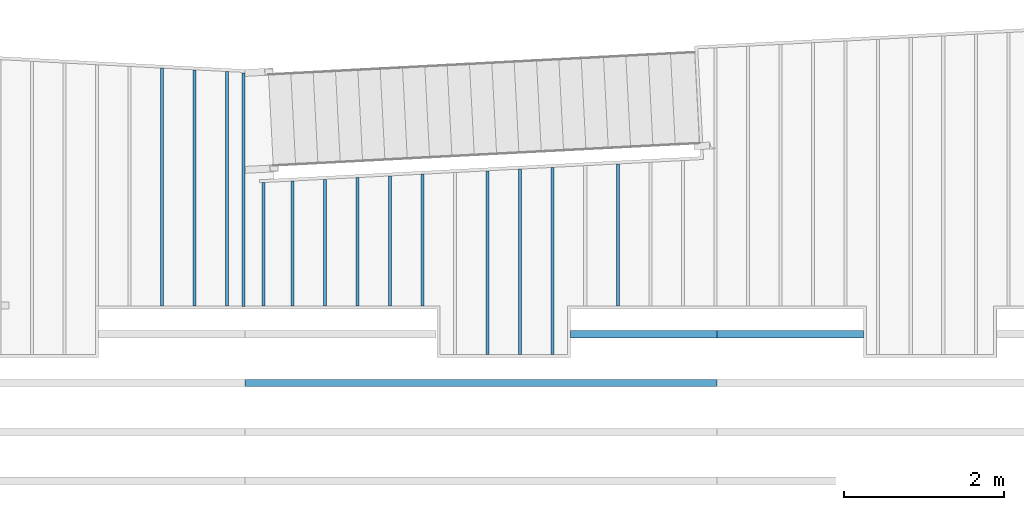
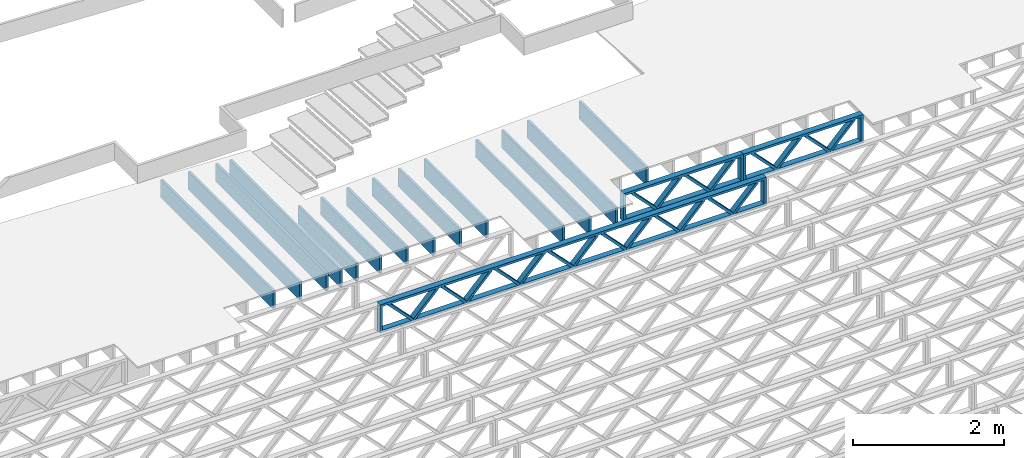
# One storey, part 5 of 23: 17 beams, 3 elements without a shape of their own.
"""IFC4 building model written with IfcOpenShell, lengths in feet."""

from ifc_helpers import new_model, entity, si_unit, converted_unit, derived_unit, direction, frame, frame_2d, origin, origin_2d_with_axis, place, context, subcontext, project, spatial, rectangle, extrude, source, transform, mapped, material, material_profile, profile_set, profile_usage, type_object, type_shapes, element, aggregate, save


model = new_model("IFC4")

# Units and contexts
model_context_1 = context("Model", 3, precision=0.0001, world=origin(), true_north=direction((6.12303176911189e-17, 1.0)))
model_context_2 = context("Model", 3, precision=0.0001, world=origin(), true_north=direction((6.12303176911189e-17, 1.0)))
body_context = subcontext(model_context_2, "Body", "Model", "MODEL_VIEW")
ifc_project = project(units=[converted_unit("LENGTHUNIT", "FOOT", entity("IfcRatioMeasure", 0.3048), si_unit("LENGTHUNIT", "METRE"), dimensions=[1, 0, 0, 0, 0, 0, 0]), converted_unit("AREAUNIT", "SQUARE FOOT", entity("IfcRatioMeasure", 0.09290304), si_unit("AREAUNIT", "SQUARE_METRE"), dimensions=[2, 0, 0, 0, 0, 0, 0]), converted_unit("VOLUMEUNIT", "CUBIC FOOT", entity("IfcRatioMeasure", 0.028316846592), si_unit("VOLUMEUNIT", "CUBIC_METRE"), dimensions=[3, 0, 0, 0, 0, 0, 0]), converted_unit("PLANEANGLEUNIT", "DEGREE", entity("IfcRatioMeasure", 0.0174532925199433), si_unit("PLANEANGLEUNIT", "RADIAN"), dimensions=[0, 0, 0, 0, 0, 0, 0]), si_unit("MASSUNIT", "GRAM", prefix="KILO"), derived_unit("MASSDENSITYUNIT", [(si_unit("MASSUNIT", "GRAM", prefix="KILO"), 1), (si_unit("LENGTHUNIT", "METRE"), -3)]), derived_unit("MOMENTOFINERTIAUNIT", [(si_unit("LENGTHUNIT", "METRE"), 4)]), si_unit("TIMEUNIT", "SECOND"), si_unit("FREQUENCYUNIT", "HERTZ"), si_unit("THERMODYNAMICTEMPERATUREUNIT", "DEGREE_CELSIUS"), derived_unit("THERMALTRANSMITTANCEUNIT", [(si_unit("MASSUNIT", "GRAM", prefix="KILO"), 1), (si_unit("THERMODYNAMICTEMPERATUREUNIT", "KELVIN"), -1), (si_unit("TIMEUNIT", "SECOND"), -3)]), derived_unit("VOLUMETRICFLOWRATEUNIT", [(si_unit("LENGTHUNIT", "METRE"), 3), (si_unit("TIMEUNIT", "SECOND"), -1)]), si_unit("ELECTRICCURRENTUNIT", "AMPERE"), si_unit("ELECTRICVOLTAGEUNIT", "VOLT"), si_unit("POWERUNIT", "WATT"), si_unit("FORCEUNIT", "NEWTON"), si_unit("ILLUMINANCEUNIT", "LUX"), si_unit("LUMINOUSFLUXUNIT", "LUMEN"), si_unit("LUMINOUSINTENSITYUNIT", "CANDELA"), derived_unit("USERDEFINED", [(si_unit("MASSUNIT", "GRAM", prefix="KILO"), -1), (si_unit("LENGTHUNIT", "METRE"), -2), (si_unit("TIMEUNIT", "SECOND"), 3), (si_unit("LUMINOUSFLUXUNIT", "LUMEN"), 1)]), derived_unit("LINEARVELOCITYUNIT", [(si_unit("LENGTHUNIT", "METRE"), 1), (si_unit("TIMEUNIT", "SECOND"), -1)]), si_unit("PRESSUREUNIT", "PASCAL"), derived_unit("USERDEFINED", [(si_unit("LENGTHUNIT", "METRE"), -2), (si_unit("MASSUNIT", "GRAM", prefix="KILO"), 1), (si_unit("TIMEUNIT", "SECOND"), -2)]), derived_unit("LINEARFORCEUNIT", [(si_unit("MASSUNIT", "GRAM", prefix="KILO"), 1), (si_unit("LENGTHUNIT", "METRE"), 1), (si_unit("TIMEUNIT", "SECOND"), -2), (si_unit("LENGTHUNIT", "METRE"), -1)]), derived_unit("PLANARFORCEUNIT", [(si_unit("MASSUNIT", "GRAM", prefix="KILO"), 1), (si_unit("LENGTHUNIT", "METRE"), 1), (si_unit("TIMEUNIT", "SECOND"), -2), (si_unit("LENGTHUNIT", "METRE"), -2)])], contexts=[model_context_1])

# Site, building, storey
site_placement = place(None, origin())
site = spatial("IfcSite", under=ifc_project, at=site_placement, CompositionType="ELEMENT")
building_placement = place(site_placement, origin())
building = spatial("IfcBuilding", under=site, at=building_placement, CompositionType="ELEMENT")
storey_placement = place(building_placement, frame((0.0, 0.0, 10.8020833333333)))
storey = spatial("IfcBuildingStorey", under=building, at=storey_placement, Name="2ND FLOOR", CompositionType="ELEMENT", Elevation=10.8020833333333)

# Assembly, beams
assembly_1_placement = place(storey_placement, origin())
assembly_1 = element("IfcElementAssembly", 1, at=assembly_1_placement, inside=storey, Name="Structural Beam System:Structural Framing System", ObjectType="Structural Beam System:Structural Framing System", AssemblyPlace="NOTDEFINED", PredefinedType="BEAM_GRID")
ifc_material_1 = material(Category="Materials")
ifc_material_profile_1 = material_profile(ifc_material_1, rectangle(XDim=0.9375, YDim=0.125000000000011, at=origin_2d_with_axis()))
ifc_profile_set_1 = profile_set([ifc_material_profile_1])
ifc_profile_usage_1 = profile_usage(ifc_profile_set_1, cardinal=8)
beam_type_1 = type_object("IfcBeamType", PredefinedType="BEAM", material=ifc_profile_set_1)
shared_shape_1 = source(origin(), body_context, "Body", "SweptSolid", [
    extrude(rectangle(XDim=0.9375, YDim=0.125000000000011, at=origin_2d_with_axis()), frame((-2.90398529415785, 0.0, 0.0), z_axis=(1.0, 0.0, 0.0), x_axis=(0.0, 0.0, -1.0)), (0.0, 0.0, 1.0), 5.8079705883157),
])
type_shapes(beam_type_1, [shared_shape_1])
beam_1_placement = place(assembly_1_placement, frame((-226.467327152129, 961.932589761828, -0.729166666666744), z_axis=(0.0, 0.0, 1.0), x_axis=(0.0, 1.0, 0.0)))
beam_1 = element("IfcBeam", 2, at=beam_1_placement, type_object=beam_type_1, material=ifc_profile_usage_1, PredefinedType="BEAM", context=body_context, shape_type="MappedRepresentation", body=[
    mapped(shared_shape_1, transform((0.0, 0.0, 0.0), scale=1.0)),
])
ifc_profile_usage_2 = profile_usage(ifc_profile_set_1, cardinal=8)
beam_type_2 = type_object("IfcBeamType", PredefinedType="BEAM", material=ifc_profile_set_1)
shared_shape_2 = source(origin(), body_context, "Body", "SweptSolid", [
    extrude(rectangle(XDim=0.9375, YDim=0.125000000000011, at=origin_2d_with_axis()), frame((-4.86630502037076, 0.0, 0.0), z_axis=(1.0, 0.0, 0.0), x_axis=(0.0, 0.0, -1.0)), (0.0, 0.0, 1.0), 9.73261004074152),
])
type_shapes(beam_type_2, [shared_shape_2])
beam_2_placement = place(assembly_1_placement, frame((-245.133993818795, 963.894909190037, -0.729166666666744), z_axis=(0.0, 0.0, 1.0), x_axis=(0.0, 1.0, 0.0)))
beam_2 = element("IfcBeam", 3, at=beam_2_placement, type_object=beam_type_2, material=ifc_profile_usage_2, PredefinedType="BEAM", context=body_context, shape_type="MappedRepresentation", body=[
    mapped(shared_shape_2, transform((0.0, 0.0, 0.0), scale=1.0)),
])

# Assembly, beam
assembly_2_placement = place(storey_placement, origin())
assembly_2 = element("IfcElementAssembly", 4, at=assembly_2_placement, inside=storey, Name="Structural Beam System:Structural Framing System", ObjectType="Structural Beam System:Structural Framing System", AssemblyPlace="NOTDEFINED", PredefinedType="BEAM_GRID")
ifc_material_2 = material(Name="WOOD TRUSS", Category="Materials")
ifc_material_profile_2 = material_profile(ifc_material_2, rectangle(XDim=1.73473973950632, YDim=0.125, at=frame_2d((-1.11022302462516e-16, 8.32667268468867e-17), x_axis=(1.0, 0.0))))
ifc_material_profile_3 = material_profile(ifc_material_2, rectangle(XDim=1.73473973950633, YDim=0.125, at=frame_2d((-1.11022302462516e-16, 8.32667268468867e-17), x_axis=(1.0, 0.0))))
ifc_material_profile_4 = material_profile(ifc_material_2, rectangle(XDim=1.73473973950632, YDim=0.125, at=frame_2d((-5.55111512312578e-17, 1.38777878078145e-16), x_axis=(1.0, 0.0))))
ifc_material_profile_5 = material_profile(ifc_material_2, rectangle(XDim=1.73473973950633, YDim=0.125, at=frame_2d((-1.11022302462516e-16, 8.32667268468867e-17), x_axis=(1.0, 0.0))))
ifc_material_profile_6 = material_profile(ifc_material_2, rectangle(XDim=1.73473973950632, YDim=0.125, at=frame_2d((-1.11022302462516e-16, 8.32667268468867e-17), x_axis=(1.0, 0.0))))
ifc_material_profile_7 = material_profile(ifc_material_2, rectangle(XDim=1.73473973950633, YDim=0.125, at=frame_2d((-2.77555756156289e-16, 3.05311331771918e-16), x_axis=(1.0, 0.0))))
ifc_material_profile_8 = material_profile(ifc_material_2, rectangle(XDim=1.73473973950632, YDim=0.124999999999999, at=frame_2d((-3.88578058618805e-16, -2.4980018054066e-16), x_axis=(1.0, 0.0))))
ifc_material_profile_9 = material_profile(ifc_material_2, rectangle(XDim=1.73473973950633, YDim=0.125, at=frame_2d((2.77555756156289e-16, -3.05311331771918e-16), x_axis=(1.0, 0.0))))
ifc_material_profile_10 = material_profile(ifc_material_2, rectangle(XDim=1.73473973950632, YDim=0.124999999999999, at=frame_2d((-1.11022302462516e-16, 8.32667268468867e-17), x_axis=(1.0, 0.0))))
ifc_material_profile_11 = material_profile(ifc_material_2, rectangle(XDim=1.73473973950633, YDim=0.125, at=origin_2d_with_axis()))
ifc_material_profile_12 = material_profile(ifc_material_2, rectangle(XDim=0.124999999999982, YDim=0.291666666666668, at=origin_2d_with_axis()))
ifc_material_profile_13 = material_profile(ifc_material_2, rectangle(XDim=0.124999999999932, YDim=0.291666666666664, at=origin_2d_with_axis()))
ifc_material_profile_14 = material_profile(ifc_material_2, rectangle(XDim=1.25000000000002, YDim=0.29166666666667, at=origin_2d_with_axis()))
ifc_material_profile_15 = material_profile(ifc_material_2, rectangle(XDim=1.25000000000004, YDim=0.291666666666667, at=origin_2d_with_axis()))
ifc_profile_set_2 = profile_set([ifc_material_profile_2, ifc_material_profile_3, ifc_material_profile_4, ifc_material_profile_5, ifc_material_profile_6, ifc_material_profile_7, ifc_material_profile_8, ifc_material_profile_9, ifc_material_profile_10, ifc_material_profile_11, ifc_material_profile_12, ifc_material_profile_13, ifc_material_profile_14, ifc_material_profile_15])
ifc_profile_usage_3 = profile_usage(ifc_profile_set_2, cardinal=8)
beam_type_3 = type_object("IfcBeamType", PredefinedType="BEAM", material=ifc_profile_set_2)
shared_shape_3 = source(origin(), body_context, "Body", "SweptSolid", [
    extrude(rectangle(XDim=1.73473973950632, YDim=0.125, at=frame_2d((0.0, 1.66533453693773e-16), x_axis=(1.0, 0.0))), frame((1.95847610985504, -0.145833333333334, 0.0), z_axis=(0.0, 1.0, 0.0), x_axis=(0.693383046997606, 0.0, 0.720569184836762)), (0.0, 0.0, 1.0), 0.291666666666667),
    extrude(rectangle(XDim=1.73473973950633, YDim=0.125, at=frame_2d((-5.55111512312578e-17, 8.32667268468867e-17), x_axis=(1.0, 0.0))), frame((0.708190236181772, -0.145833333333334, 0.0), z_axis=(0.0, 1.0, 0.0), x_axis=(0.69338304699761, 0.0, -0.720569184836758)), (0.0, 0.0, 1.0), 0.291666666666667),
    extrude(rectangle(XDim=1.73473973950632, YDim=0.125, at=frame_2d((0.0, 1.66533453693773e-16), x_axis=(1.0, 0.0))), frame((-0.708190236181118, -0.145833333333334, 0.0), z_axis=(0.0, 1.0, 0.0), x_axis=(0.693383046997606, 0.0, 0.720569184836762)), (0.0, 0.0, 1.0), 0.291666666666667),
    extrude(rectangle(XDim=1.73473973950633, YDim=0.125, at=frame_2d((-2.22044604925031e-16, 2.22044604925031e-16), x_axis=(1.0, 0.0))), frame((-1.95847610985439, -0.145833333333334, 0.0), z_axis=(0.0, 1.0, 0.0), x_axis=(0.69338304699761, 0.0, -0.720569184836758)), (0.0, 0.0, 1.0), 0.291666666666666),
    extrude(rectangle(XDim=0.124999999999982, YDim=0.291666666666668, at=origin_2d_with_axis()), frame((-2.99999983968466, 0.0, 0.687500000000054), z_axis=(1.0, 0.0, 0.0), x_axis=(0.0, 0.0, -1.0)), (0.0, 0.0, 1.0), 5.99999967936932),
    extrude(rectangle(XDim=0.124999999999932, YDim=0.291666666666664, at=origin_2d_with_axis()), frame((-2.99999983968445, 0.0, -0.687499999999984), z_axis=(1.0, 0.0, 0.0), x_axis=(0.0, 0.0, -1.0)), (0.0, 0.0, 1.0), 5.99999967936911),
    extrude(rectangle(XDim=1.25000000000002, YDim=0.29166666666667, at=origin_2d_with_axis()), frame((2.87499983968464, 0.0, 0.0), z_axis=(1.0, 0.0, 0.0), x_axis=(0.0, 0.0, -1.0)), (0.0, 0.0, 1.0), 0.12500000000002),
    extrude(rectangle(XDim=1.25000000000004, YDim=0.291666666666667, at=origin_2d_with_axis()), frame((-2.99999983968466, 0.0, 0.0), z_axis=(1.0, 0.0, 0.0), x_axis=(0.0, 0.0, -1.0)), (0.0, 0.0, 1.0), 0.125000000000023),
])
type_shapes(beam_type_3, [shared_shape_3])
beam_3_placement = place(assembly_2_placement, frame((-219.404827312476, 957.861934882651, -0.947916666666872), z_axis=(0.0, 0.0, 1.0), x_axis=(-1.0, 0.0, 0.0)))
beam_3 = element("IfcBeam", 5, at=beam_3_placement, type_object=beam_type_3, material=ifc_profile_usage_3, PredefinedType="BEAM", context=body_context, shape_type="MappedRepresentation", body=[
    mapped(shared_shape_3, transform((0.0, 0.0, 0.0), scale=1.0)),
])
aggregate(assembly_2, [beam_3])

# Beam
ifc_profile_usage_4 = profile_usage(ifc_profile_set_1, cardinal=8)
beam_type_4 = type_object("IfcBeamType", PredefinedType="BEAM", material=ifc_profile_set_1)
shared_shape_4 = source(origin(), body_context, "Body", "SweptSolid", [
    extrude(rectangle(XDim=0.9375, YDim=0.125000000000011, at=origin_2d_with_axis()), frame((-3.83410971429021, 0.0, 0.0), z_axis=(1.0, 0.0, 0.0), x_axis=(0.0, 0.0, -1.0)), (0.0, 0.0, 1.0), 7.66821942858041),
])
type_shapes(beam_type_4, [shared_shape_4])
beam_4_placement = place(assembly_1_placement, frame((-229.133993818795, 960.862711263608, -0.729166666666744), z_axis=(0.0, 0.0, 1.0), x_axis=(0.0, 1.0, 0.0)))
beam_4 = element("IfcBeam", 6, at=beam_4_placement, type_object=beam_type_4, material=ifc_profile_usage_4, PredefinedType="BEAM", context=body_context, shape_type="MappedRepresentation", body=[
    mapped(shared_shape_4, transform((0.0, 0.0, 0.0), scale=1.0)),
])

ifc_profile_usage_5 = profile_usage(ifc_profile_set_1, cardinal=8)
beam_type_5 = type_object("IfcBeamType", PredefinedType="BEAM", material=ifc_profile_set_1)
shared_shape_5 = source(origin(), body_context, "Body", "SweptSolid", [
    extrude(rectangle(XDim=0.9375, YDim=0.125000000000011, at=origin_2d_with_axis()), frame((-3.76423267524643, 0.0, 0.0), z_axis=(1.0, 0.0, 0.0), x_axis=(0.0, 0.0, -1.0)), (0.0, 0.0, 1.0), 7.52846535049287),
])
type_shapes(beam_type_5, [shared_shape_5])
beam_5_placement = place(assembly_1_placement, frame((-231.800660485462, 960.792834224564, -0.729166666666744), z_axis=(0.0, 0.0, 1.0), x_axis=(0.0, 1.0, 0.0)))
beam_5 = element("IfcBeam", 7, at=beam_5_placement, type_object=beam_type_5, material=ifc_profile_usage_5, PredefinedType="BEAM", context=body_context, shape_type="MappedRepresentation", body=[
    mapped(shared_shape_5, transform((0.0, 0.0, 0.0), scale=1.0)),
])

ifc_profile_usage_6 = profile_usage(ifc_profile_set_1, cardinal=8)
beam_type_6 = type_object("IfcBeamType", PredefinedType="BEAM", material=ifc_profile_set_1)
shared_shape_6 = source(origin(), body_context, "Body", "SweptSolid", [
    extrude(rectangle(XDim=0.9375, YDim=0.125000000000011, at=origin_2d_with_axis()), frame((-2.69435432602859, 0.0, 0.0), z_axis=(1.0, 0.0, 0.0), x_axis=(0.0, 0.0, -1.0)), (0.0, 0.0, 1.0), 5.38870865205718),
])
type_shapes(beam_type_6, [shared_shape_6])
beam_6_placement = place(assembly_1_placement, frame((-234.467327152129, 961.722958495694, -0.729166666666744), z_axis=(0.0, 0.0, 1.0), x_axis=(0.0, 1.0, 0.0)))
beam_6 = element("IfcBeam", 8, at=beam_6_placement, type_object=beam_type_6, material=ifc_profile_usage_6, PredefinedType="BEAM", context=body_context, shape_type="MappedRepresentation", body=[
    mapped(shared_shape_6, transform((0.0, 0.0, 0.0), scale=1.0)),
])

ifc_profile_usage_7 = profile_usage(ifc_profile_set_1, cardinal=8)
beam_type_7 = type_object("IfcBeamType", PredefinedType="BEAM", material=ifc_profile_set_1)
shared_shape_7 = source(origin(), body_context, "Body", "SweptSolid", [
    extrude(rectangle(XDim=0.9375, YDim=0.125000000000011, at=origin_2d_with_axis()), frame((-2.65941580650667, 0.0, 0.0), z_axis=(1.0, 0.0, 0.0), x_axis=(0.0, 0.0, -1.0)), (0.0, 0.0, 1.0), 5.31883161301334),
])
type_shapes(beam_type_7, [shared_shape_7])
beam_7_placement = place(assembly_1_placement, frame((-235.800660485462, 961.688019976173, -0.729166666666744), z_axis=(0.0, 0.0, 1.0), x_axis=(0.0, 1.0, 0.0)))
beam_7 = element("IfcBeam", 9, at=beam_7_placement, type_object=beam_type_7, material=ifc_profile_usage_7, PredefinedType="BEAM", context=body_context, shape_type="MappedRepresentation", body=[
    mapped(shared_shape_7, transform((0.0, 0.0, 0.0), scale=1.0)),
])

ifc_profile_usage_8 = profile_usage(ifc_profile_set_1, cardinal=8)
beam_type_8 = type_object("IfcBeamType", PredefinedType="BEAM", material=ifc_profile_set_1)
shared_shape_8 = source(origin(), body_context, "Body", "SweptSolid", [
    extrude(rectangle(XDim=0.9375, YDim=0.125000000000011, at=origin_2d_with_axis()), frame((-2.62447728698476, 0.0, 0.0), z_axis=(1.0, 0.0, 0.0), x_axis=(0.0, 0.0, -1.0)), (0.0, 0.0, 1.0), 5.24895457396951),
])
type_shapes(beam_type_8, [shared_shape_8])
beam_8_placement = place(assembly_1_placement, frame((-237.133993818795, 961.653081456651, -0.729166666666744), z_axis=(0.0, 0.0, 1.0), x_axis=(0.0, 1.0, 0.0)))
beam_8 = element("IfcBeam", 10, at=beam_8_placement, type_object=beam_type_8, material=ifc_profile_usage_8, PredefinedType="BEAM", context=body_context, shape_type="MappedRepresentation", body=[
    mapped(shared_shape_8, transform((0.0, 0.0, 0.0), scale=1.0)),
])

ifc_profile_usage_9 = profile_usage(ifc_profile_set_1, cardinal=8)
beam_type_9 = type_object("IfcBeamType", PredefinedType="BEAM", material=ifc_profile_set_1)
shared_shape_9 = source(origin(), body_context, "Body", "SweptSolid", [
    extrude(rectangle(XDim=0.9375, YDim=0.125000000000011, at=origin_2d_with_axis()), frame((-4.79642798132676, 0.0, 0.0), z_axis=(1.0, 0.0, 0.0), x_axis=(0.0, 0.0, -1.0)), (0.0, 0.0, 1.0), 9.59285596265352),
])
type_shapes(beam_type_9, [shared_shape_9])
beam_9_placement = place(assembly_1_placement, frame((-242.467327152129, 963.825032150993, -0.729166666666744), z_axis=(0.0, 0.0, 1.0), x_axis=(0.0, 1.0, 0.0)))
beam_9 = element("IfcBeam", 11, at=beam_9_placement, type_object=beam_type_9, material=ifc_profile_usage_9, PredefinedType="BEAM", context=body_context, shape_type="MappedRepresentation", body=[
    mapped(shared_shape_9, transform((0.0, 0.0, 0.0), scale=1.0)),
])

ifc_profile_usage_10 = profile_usage(ifc_profile_set_1, cardinal=8)
beam_type_10 = type_object("IfcBeamType", PredefinedType="BEAM", material=ifc_profile_set_1)
shared_shape_10 = source(origin(), body_context, "Body", "SweptSolid", [
    extrude(rectangle(XDim=0.9375, YDim=0.125000000000011, at=origin_2d_with_axis()), frame((-4.83136650084879, 0.0, 0.0), z_axis=(1.0, 0.0, 0.0), x_axis=(0.0, 0.0, -1.0)), (0.0, 0.0, 1.0), 9.66273300169757),
])
type_shapes(beam_type_10, [shared_shape_10])
beam_10_placement = place(assembly_1_placement, frame((-243.800660485462, 963.859970670515, -0.729166666666744), z_axis=(0.0, 0.0, 1.0), x_axis=(0.0, 1.0, 0.0)))
beam_10 = element("IfcBeam", 12, at=beam_10_placement, type_object=beam_type_10, material=ifc_profile_usage_10, PredefinedType="BEAM", context=body_context, shape_type="MappedRepresentation", body=[
    mapped(shared_shape_10, transform((0.0, 0.0, 0.0), scale=1.0)),
])

ifc_profile_usage_11 = profile_usage(ifc_profile_set_1, cardinal=8)
beam_type_11 = type_object("IfcBeamType", PredefinedType="BEAM", material=ifc_profile_set_1)
shared_shape_11 = source(origin(), body_context, "Body", "SweptSolid", [
    extrude(rectangle(XDim=0.9375, YDim=0.125000000000011, at=origin_2d_with_axis()), frame((-2.55460024794093, 0.0, 0.0), z_axis=(1.0, 0.0, 0.0), x_axis=(0.0, 0.0, -1.0)), (0.0, 0.0, 1.0), 5.10920049588185),
])
type_shapes(beam_type_11, [shared_shape_11])
beam_11_placement = place(assembly_1_placement, frame((-239.800660485462, 961.583204417607, -0.729166666666744), z_axis=(0.0, 0.0, 1.0), x_axis=(0.0, 1.0, 0.0)))
beam_11 = element("IfcBeam", 13, at=beam_11_placement, type_object=beam_type_11, material=ifc_profile_usage_11, PredefinedType="BEAM", context=body_context, shape_type="MappedRepresentation", body=[
    mapped(shared_shape_11, transform((0.0, 0.0, 0.0), scale=1.0)),
])

ifc_profile_usage_12 = profile_usage(ifc_profile_set_1, cardinal=8)
beam_type_12 = type_object("IfcBeamType", PredefinedType="BEAM", material=ifc_profile_set_1)
shared_shape_12 = source(origin(), body_context, "Body", "SweptSolid", [
    extrude(rectangle(XDim=0.9375, YDim=0.125000000000011, at=origin_2d_with_axis()), frame((-2.58953876746284, 0.0, 0.0), z_axis=(1.0, 0.0, 0.0), x_axis=(0.0, 0.0, -1.0)), (0.0, 0.0, 1.0), 5.17907753492568),
])
type_shapes(beam_type_12, [shared_shape_12])
beam_12_placement = place(assembly_1_placement, frame((-238.467327152129, 961.618142937129, -0.729166666666744), z_axis=(0.0, 0.0, 1.0), x_axis=(0.0, 1.0, 0.0)))
beam_12 = element("IfcBeam", 14, at=beam_12_placement, type_object=beam_type_12, material=ifc_profile_usage_12, PredefinedType="BEAM", context=body_context, shape_type="MappedRepresentation", body=[
    mapped(shared_shape_12, transform((0.0, 0.0, 0.0), scale=1.0)),
])

ifc_profile_usage_13 = profile_usage(ifc_profile_set_1, cardinal=8)
beam_type_13 = type_object("IfcBeamType", PredefinedType="BEAM", material=ifc_profile_set_1)
shared_shape_13 = source(origin(), body_context, "Body", "SweptSolid", [
    extrude(rectangle(XDim=0.9375, YDim=0.125000000000011, at=origin_2d_with_axis()), frame((-3.79917119476829, 0.0, 0.0), z_axis=(1.0, 0.0, 0.0), x_axis=(0.0, 0.0, -1.0)), (0.0, 0.0, 1.0), 7.59834238953658),
])
type_shapes(beam_type_13, [shared_shape_13])
beam_13_placement = place(assembly_1_placement, frame((-230.467327152129, 960.827772744086, -0.729166666666744), z_axis=(0.0, 0.0, 1.0), x_axis=(0.0, 1.0, 0.0)))
beam_13 = element("IfcBeam", 15, at=beam_13_placement, type_object=beam_type_13, material=ifc_profile_usage_13, PredefinedType="BEAM", context=body_context, shape_type="MappedRepresentation", body=[
    mapped(shared_shape_13, transform((0.0, 0.0, 0.0), scale=1.0)),
])

aggregate(assembly_1, [beam_1, beam_2, beam_4, beam_5, beam_6, beam_7, beam_8, beam_9, beam_10, beam_11, beam_12, beam_13])

# Beams
ifc_profile_usage_14 = profile_usage(ifc_profile_set_1, cardinal=8)
beam_type_14 = type_object("IfcBeamType", PredefinedType="BEAM", material=ifc_profile_set_1)
shared_shape_14 = source(origin(), body_context, "Body", "SweptSolid", [
    extrude(rectangle(XDim=0.9375, YDim=0.125000000000011, at=frame_2d((-8.32667268468867e-17, 0.0), x_axis=(1.0, 0.0))), frame((-2.52389187218054, 0.0, 0.0), z_axis=(1.0, 0.0, 0.0), x_axis=(0.0, 0.0, -1.0)), (0.0, 0.0, 1.0), 5.04778374436108),
])
type_shapes(beam_type_14, [shared_shape_14])
beam_14_placement = place(storey_placement, frame((-240.972506076923, 961.552497128989, -0.729166666666742), z_axis=(0.0, 0.0, 1.0), x_axis=(-1.39070708966994e-05, 1.0, 0.0)))
element("IfcBeam", 16, at=beam_14_placement, inside=storey, type_object=beam_type_14, material=ifc_profile_usage_14, PredefinedType="BEAM", context=body_context, shape_type="MappedRepresentation", body=[
    mapped(shared_shape_14, transform((0.0, 0.0, 0.0), scale=1.0)),
])
ifc_profile_usage_15 = profile_usage(ifc_profile_set_1, cardinal=8)
beam_type_15 = type_object("IfcBeamType", PredefinedType="BEAM", material=ifc_profile_set_1)
shared_shape_15 = source(origin(), body_context, "Body", "SweptSolid", [
    extrude(rectangle(XDim=0.9375, YDim=0.125000000000011, at=origin_2d_with_axis()), frame((-4.78526668789971, 0.0, 0.0), z_axis=(1.0, 0.0, 0.0), x_axis=(0.0, 0.0, -1.0)), (0.0, 0.0, 1.0), 9.57053337579941),
])
type_shapes(beam_type_15, [shared_shape_15])
beam_15_placement = place(storey_placement, frame((-241.800660485529, 963.778932338047, -0.729166666666744), z_axis=(0.0, 0.0, 1.0), x_axis=(0.0, 1.0, 0.0)))
element("IfcBeam", 17, at=beam_15_placement, inside=storey, type_object=beam_type_15, material=ifc_profile_usage_15, PredefinedType="BEAM", context=body_context, shape_type="MappedRepresentation", body=[
    mapped(shared_shape_15, transform((0.0, 0.0, 0.0), scale=1.0)),
])

# Assembly, beams
assembly_3_placement = place(storey_placement, origin())
assembly_3 = element("IfcElementAssembly", 18, at=assembly_3_placement, inside=storey, Name="Structural Beam System:Structural Framing System", ObjectType="Structural Beam System:Structural Framing System", AssemblyPlace="NOTDEFINED", PredefinedType="BEAM_GRID")
ifc_profile_usage_16 = profile_usage(ifc_profile_set_2, cardinal=8)
beam_type_16 = type_object("IfcBeamType", PredefinedType="BEAM", material=ifc_profile_set_2)
shared_shape_16 = source(origin(), body_context, "Body", "SweptSolid", [
    extrude(rectangle(XDim=1.73473973950632, YDim=0.125, at=frame_2d((0.0, 1.66533453693773e-16), x_axis=(1.0, 0.0))), frame((1.95847612494153, -0.145833333333334, 0.0), z_axis=(0.0, 1.0, 0.0), x_axis=(0.693383046997606, 0.0, 0.720569184836762)), (0.0, 0.0, 1.0), 0.291666666666667),
    extrude(rectangle(XDim=1.73473973950633, YDim=0.125, at=frame_2d((-5.55111512312578e-17, 8.32667268468867e-17), x_axis=(1.0, 0.0))), frame((0.708190251268258, -0.145833333333334, 0.0), z_axis=(0.0, 1.0, 0.0), x_axis=(0.69338304699761, 0.0, -0.720569184836758)), (0.0, 0.0, 1.0), 0.291666666666667),
    extrude(rectangle(XDim=1.73473973950632, YDim=0.125, at=frame_2d((0.0, 1.66533453693773e-16), x_axis=(1.0, 0.0))), frame((-0.708190251267602, -0.145833333333334, 0.0), z_axis=(0.0, 1.0, 0.0), x_axis=(0.693383046997606, 0.0, 0.720569184836762)), (0.0, 0.0, 1.0), 0.291666666666667),
    extrude(rectangle(XDim=1.73473973950633, YDim=0.125, at=frame_2d((-2.22044604925031e-16, 2.22044604925031e-16), x_axis=(1.0, 0.0))), frame((-1.95847612494087, -0.145833333333334, 0.0), z_axis=(0.0, 1.0, 0.0), x_axis=(0.69338304699761, 0.0, -0.720569184836758)), (0.0, 0.0, 1.0), 0.291666666666666),
    extrude(rectangle(XDim=0.124999999999982, YDim=0.291666666666668, at=origin_2d_with_axis()), frame((-2.99999985477115, 0.0, 0.687500000000054), z_axis=(1.0, 0.0, 0.0), x_axis=(0.0, 0.0, -1.0)), (0.0, 0.0, 1.0), 5.99999970954229),
    extrude(rectangle(XDim=0.124999999999932, YDim=0.291666666666664, at=origin_2d_with_axis()), frame((-2.99999985477093, 0.0, -0.687499999999984), z_axis=(1.0, 0.0, 0.0), x_axis=(0.0, 0.0, -1.0)), (0.0, 0.0, 1.0), 5.99999970954208),
    extrude(rectangle(XDim=1.25000000000002, YDim=0.29166666666667, at=origin_2d_with_axis()), frame((2.87499985477113, 0.0, 0.0), z_axis=(1.0, 0.0, 0.0), x_axis=(0.0, 0.0, -1.0)), (0.0, 0.0, 1.0), 0.12500000000002),
    extrude(rectangle(XDim=1.25000000000004, YDim=0.291666666666667, at=origin_2d_with_axis()), frame((-2.99999985477115, 0.0, 0.0), z_axis=(1.0, 0.0, 0.0), x_axis=(0.0, 0.0, -1.0)), (0.0, 0.0, 1.0), 0.125000000000023),
])
type_shapes(beam_type_16, [shared_shape_16])
beam_16_placement = place(assembly_3_placement, frame((-225.404826976829, 957.861934882651, -0.947916666666648)))
beam_16 = element("IfcBeam", 19, at=beam_16_placement, type_object=beam_type_16, material=ifc_profile_usage_16, PredefinedType="BEAM", context=body_context, shape_type="MappedRepresentation", body=[
    mapped(shared_shape_16, transform((0.0, 0.0, 0.0), scale=1.0)),
])
ifc_profile_usage_17 = profile_usage(ifc_profile_set_2, cardinal=8)
beam_type_17 = type_object("IfcBeamType", PredefinedType="BEAM", material=ifc_profile_set_2)
shared_shape_17 = source(origin(), body_context, "Body", "SweptSolid", [
    extrude(rectangle(XDim=1.73473973950632, YDim=0.124999999999999, at=frame_2d((5.55111512312578e-16, 7.21644966006352e-16), x_axis=(1.0, 0.0))), frame((5.95847627016997, -0.145833333333334, 0.0), z_axis=(0.0, 1.0, 0.0), x_axis=(0.693383046997606, 0.0, 0.720569184836762)), (0.0, 0.0, 1.0), 0.291666666666667),
    extrude(rectangle(XDim=1.73473973950633, YDim=0.125, at=origin_2d_with_axis()), frame((4.7081903964967, -0.145833333333334, 0.0), z_axis=(0.0, 1.0, 0.0), x_axis=(0.69338304699761, 0.0, -0.720569184836758)), (0.0, 0.0, 1.0), 0.291666666666666),
    extrude(rectangle(XDim=1.73473973950632, YDim=0.125, at=frame_2d((2.22044604925031e-16, 3.88578058618805e-16), x_axis=(1.0, 0.0))), frame((3.29180960350347, -0.145833333333334, 0.0), z_axis=(0.0, 1.0, 0.0), x_axis=(0.693383046997606, 0.0, 0.720569184836762)), (0.0, 0.0, 1.0), 0.291666666666667),
    extrude(rectangle(XDim=1.73473973950633, YDim=0.125, at=frame_2d((1.11022302462516e-16, -8.32667268468867e-17), x_axis=(1.0, 0.0))), frame((2.0415237298302, -0.145833333333334, 0.0), z_axis=(0.0, 1.0, 0.0), x_axis=(0.69338304699761, 0.0, -0.720569184836758)), (0.0, 0.0, 1.0), 0.291666666666667),
    extrude(rectangle(XDim=1.73473973950632, YDim=0.125, at=frame_2d((-5.55111512312578e-17, 1.38777878078145e-16), x_axis=(1.0, 0.0))), frame((0.625142936836964, -0.145833333333334, 0.0), z_axis=(0.0, 1.0, 0.0), x_axis=(0.693383046997606, 0.0, 0.720569184836762)), (0.0, 0.0, 1.0), 0.291666666666667),
    extrude(rectangle(XDim=1.73473973950633, YDim=0.125, at=frame_2d((-1.11022302462516e-16, 8.32667268468867e-17), x_axis=(1.0, 0.0))), frame((-0.625142936836306, -0.145833333333334, 0.0), z_axis=(0.0, 1.0, 0.0), x_axis=(0.69338304699761, 0.0, -0.720569184836758)), (0.0, 0.0, 1.0), 0.291666666666667),
    extrude(rectangle(XDim=1.73473973950632, YDim=0.125, at=frame_2d((-1.11022302462516e-16, 8.32667268468867e-17), x_axis=(1.0, 0.0))), frame((-2.04152372982954, -0.145833333333334, 0.0), z_axis=(0.0, 1.0, 0.0), x_axis=(0.693383046997606, 0.0, 0.720569184836762)), (0.0, 0.0, 1.0), 0.291666666666667),
    extrude(rectangle(XDim=1.73473973950633, YDim=0.125, at=origin_2d_with_axis()), frame((-3.29180960350281, -0.145833333333334, 0.0), z_axis=(0.0, 1.0, 0.0), x_axis=(0.69338304699761, 0.0, -0.720569184836758)), (0.0, 0.0, 1.0), 0.291666666666667),
    extrude(rectangle(XDim=1.73473973950632, YDim=0.124999999999999, at=frame_2d((-1.11022302462516e-16, 8.32667268468867e-17), x_axis=(1.0, 0.0))), frame((-4.70819039649604, -0.145833333333334, 0.0), z_axis=(0.0, 1.0, 0.0), x_axis=(0.693383046997606, 0.0, 0.720569184836762)), (0.0, 0.0, 1.0), 0.291666666666667),
    extrude(rectangle(XDim=1.73473973950633, YDim=0.125, at=frame_2d((-5.55111512312578e-16, 6.38378239159465e-16), x_axis=(1.0, 0.0))), frame((-5.95847627016931, -0.145833333333334, 0.0), z_axis=(0.0, 1.0, 0.0), x_axis=(0.69338304699761, 0.0, -0.720569184836758)), (0.0, 0.0, 1.0), 0.291666666666666),
    extrude(rectangle(XDim=1.73473973950632, YDim=0.125, at=frame_2d((-7.21644966006352e-16, -5.82867087928207e-16), x_axis=(1.0, 0.0))), frame((8.62514293683647, -0.145833333333334, 0.0), z_axis=(0.0, 1.0, 0.0), x_axis=(0.693383046997607, 0.0, 0.720569184836761)), (0.0, 0.0, 1.0), 0.291666666666667),
    extrude(rectangle(XDim=1.73473973950633, YDim=0.125, at=origin_2d_with_axis()), frame((7.3748570631632, -0.145833333333334, 0.0), z_axis=(0.0, 1.0, 0.0), x_axis=(0.69338304699761, 0.0, -0.720569184836758)), (0.0, 0.0, 1.0), 0.291666666666666),
    extrude(rectangle(XDim=1.73473973950632, YDim=0.124999999999999, at=frame_2d((-1.11022302462516e-16, 8.32667268468867e-17), x_axis=(1.0, 0.0))), frame((-7.37485706316255, -0.145833333333334, 0.0), z_axis=(0.0, 1.0, 0.0), x_axis=(0.693383046997606, 0.0, 0.720569184836762)), (0.0, 0.0, 1.0), 0.291666666666667),
    extrude(rectangle(XDim=1.73473973950633, YDim=0.125, at=origin_2d_with_axis()), frame((-8.62514293683582, -0.145833333333334, 0.0), z_axis=(0.0, 1.0, 0.0), x_axis=(0.69338304699761, 0.0, -0.720569184836758)), (0.0, 0.0, 1.0), 0.291666666666666),
    extrude(rectangle(XDim=0.124999999999982, YDim=0.291666666666668, at=origin_2d_with_axis()), frame((-9.66666666666609, 0.0, 0.687500000000054), z_axis=(1.0, 0.0, 0.0), x_axis=(0.0, 0.0, -1.0)), (0.0, 0.0, 1.0), 19.3333333333322),
    extrude(rectangle(XDim=0.124999999999932, YDim=0.291666666666664, at=origin_2d_with_axis()), frame((-9.66666666666588, 0.0, -0.687499999999984), z_axis=(1.0, 0.0, 0.0), x_axis=(0.0, 0.0, -1.0)), (0.0, 0.0, 1.0), 19.333333333332),
    extrude(rectangle(XDim=1.25000000000002, YDim=0.29166666666667, at=origin_2d_with_axis()), frame((9.54166666666607, 0.0, 0.0), z_axis=(1.0, 0.0, 0.0), x_axis=(0.0, 0.0, -1.0)), (0.0, 0.0, 1.0), 0.12500000000002),
    extrude(rectangle(XDim=1.25000000000004, YDim=0.291666666666667, at=origin_2d_with_axis()), frame((-9.66666666666609, 0.0, 0.0), z_axis=(1.0, 0.0, 0.0), x_axis=(0.0, 0.0, -1.0)), (0.0, 0.0, 1.0), 0.125000000000023),
])
type_shapes(beam_type_17, [shared_shape_17])
beam_17_placement = place(assembly_3_placement, frame((-232.071493788723, 955.861934882651, -0.947916666666657)))
beam_17 = element("IfcBeam", 20, at=beam_17_placement, type_object=beam_type_17, material=ifc_profile_usage_17, PredefinedType="BEAM", context=body_context, shape_type="MappedRepresentation", body=[
    mapped(shared_shape_17, transform((0.0, 0.0, 0.0), scale=1.0)),
])
aggregate(assembly_3, [beam_16, beam_17])

save(model, "model.ifc")
